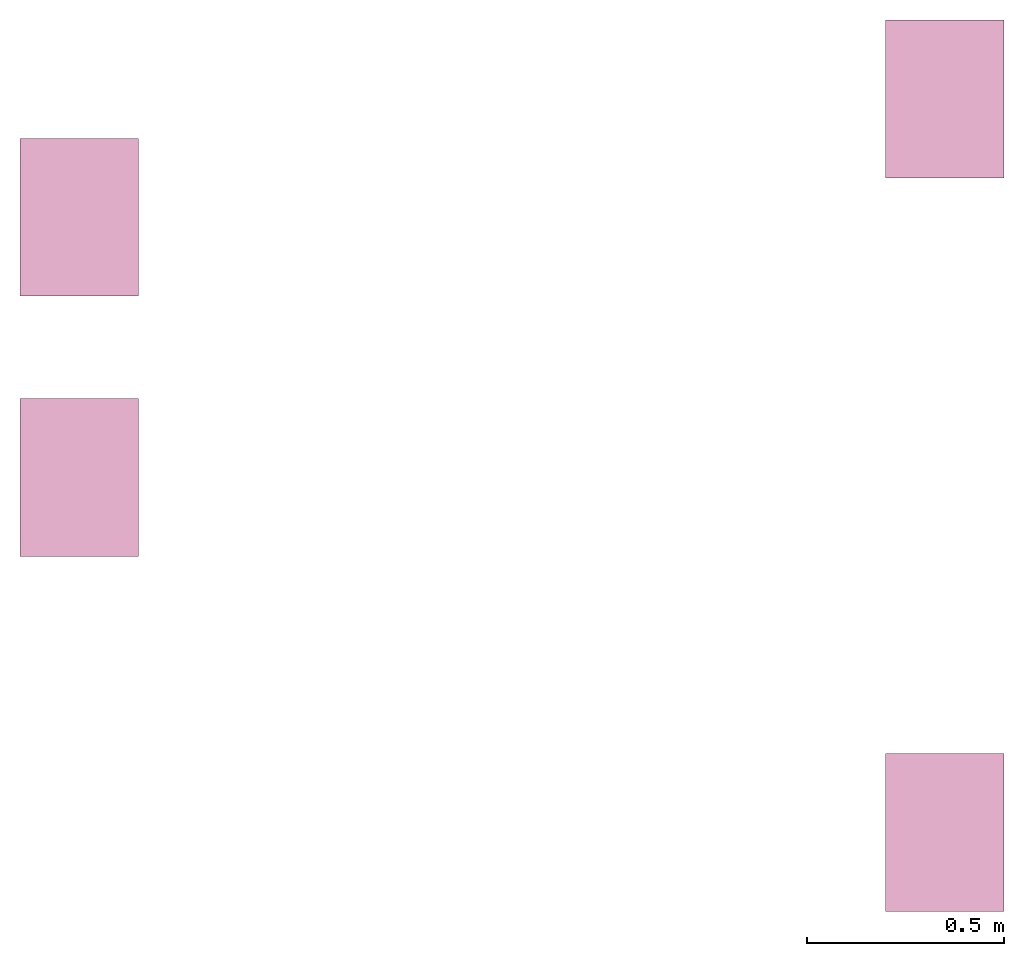
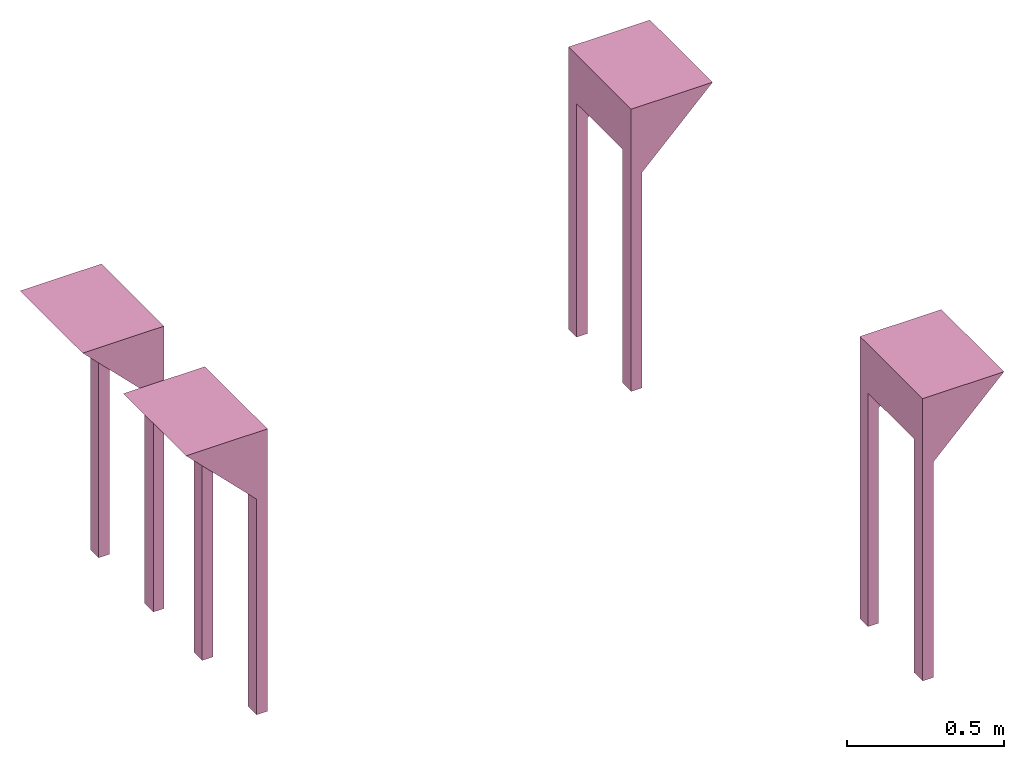
# One storey: 4 furnishings.
"""IFC2X3 building model written with IfcOpenShell, lengths in millimetres."""

from ifc_helpers import new_model, entity, si_unit, converted_unit, money_unit, direction, frame, origin_with_axes, place, context, subcontext, project, spatial, faceted_brep, source, transform, mapped, material, type_object, element, save


model = new_model("IFC2X3")

# Units and contexts
model_context = context("Model", 3, precision=1e-05, world=origin_with_axes(), true_north=direction((0.0, 1.0)))
body_context = subcontext(model_context, "Body", "Model", "MODEL_VIEW")
ifc_project = project(units=[si_unit("LENGTHUNIT", "METRE", prefix="MILLI"), si_unit("AREAUNIT", "SQUARE_METRE"), si_unit("VOLUMEUNIT", "CUBIC_METRE"), converted_unit("PLANEANGLEUNIT", "DEGREE", entity("IfcPlaneAngleMeasure", 0.0174532925199), si_unit("PLANEANGLEUNIT", "RADIAN"), dimensions=[0, 0, 0, 0, 0, 0, 0]), si_unit("SOLIDANGLEUNIT", "STERADIAN"), money_unit("USD"), converted_unit("TIMEUNIT", "Year", entity("IfcTimeMeasure", 31556926.0), si_unit("TIMEUNIT", "SECOND"), dimensions=[0, 0, 0, 0, 0, 0, 0]), si_unit("MASSUNIT", "GRAM"), si_unit("THERMODYNAMICTEMPERATUREUNIT", "DEGREE_CELSIUS"), si_unit("LUMINOUSINTENSITYUNIT", "LUMEN")], contexts=[model_context])

# Site, building, storey
site_placement = place(None, origin_with_axes())
site = spatial("IfcSite", under=ifc_project, at=site_placement, CompositionType="ELEMENT")
building_placement = place(site_placement, origin_with_axes())
building = spatial("IfcBuilding", under=site, at=building_placement, CompositionType="ELEMENT")
storey_placement = place(building_placement, frame((0.0, 0.0, 70800.0), z_axis=(0.0, 0.0, 1.0), x_axis=(1.0, 0.0, 0.0)))
storey = spatial("IfcBuildingStorey", under=building, at=storey_placement, CompositionType="ELEMENT", Elevation=70800.0)

# Furnishings
ifc_material = material(Name="Galv Mild Steel")
furniture_type_1 = type_object("IfcFurnitureType", Name="Pump Stand", AssemblyPlace="NOTDEFINED")
shared_shape_1 = source(origin_with_axes(), body_context, "Body", "Brep", [
    faceted_brep([(0.0, 0.0, 1100.0), (0.0, 0.0, 0.0), (39.558800933, 0.0, 0.0), (39.558800933, 0.0, 839.558800933), (300.0, 0.0, 1100.0), (0.0, 400.0, 1100.0), (0.0, 400.0, 0.0), (0.0, 348.624416492, 0.0), (0.0, 348.624416492, 910.460081542), (0.0, 55.7857203565, 910.460081542), (0.0, 55.7857203565, 0.0), (39.558800933, 55.7857203565, 0.0), (39.558800933, 55.7857203565, 839.558800933), (110.460081542, 55.7857203565, 910.460081542), (110.460081542, 348.624416492, 910.460081542), (39.558800933, 348.624416492, 839.558800933), (39.558800933, 400.0, 839.558800933), (300.0, 400.0, 1100.0), (39.558800933, 400.0, 0.0), (39.558800933, 348.624416492, 0.0)], [[[0, 1, 2, 3, 4]], [[1, 0, 5, 6, 7, 8, 9, 10]], [[2, 1, 10, 11]], [[3, 2, 11, 12]], [[4, 3, 12, 13, 14, 15, 16, 17]], [[0, 4, 17, 5]], [[5, 17, 16, 18, 6]], [[6, 18, 19, 7]], [[14, 8, 7, 19, 15]], [[8, 14, 13, 9]], [[9, 13, 12, 11, 10]], [[18, 16, 15, 19]]]),
])
furnishing_1_placement = place(storey_placement, frame((8913.79615184, -236.19512708, -100.0), z_axis=(0.0, 0.0, 1.0), x_axis=(1.0, 0.0, 0.0)))
element("IfcFurnishingElement", 1, at=furnishing_1_placement, inside=storey, type_object=furniture_type_1, material=ifc_material, Name="Pump Stand4:Pump Stand", ObjectType="Pump Stand", context=body_context, shape_type="MappedRepresentation", body=[
    mapped(shared_shape_1, transform((0.0, 0.0, 0.0))),
])
furniture_type_2 = type_object("IfcFurnitureType", Name="Pump Stand", AssemblyPlace="NOTDEFINED")
furnishing_2_placement = place(storey_placement, frame((8913.79615184, 1623.80487292, -100.0), z_axis=(0.0, 0.0, 1.0), x_axis=(1.0, 0.0, 0.0)))
element("IfcFurnishingElement", 2, at=furnishing_2_placement, inside=storey, type_object=furniture_type_2, material=ifc_material, Name="Pump Stand5:Pump Stand", ObjectType="Pump Stand", context=body_context, shape_type="MappedRepresentation", body=[
    mapped(shared_shape_1, transform((0.0, 0.0, 0.0))),
])
furniture_type_3 = type_object("IfcFurnitureType", Name="Pump Stand", AssemblyPlace="NOTDEFINED")
shared_shape_2 = source(origin_with_axes(), body_context, "Body", "Brep", [
    faceted_brep([(300.000043889, 3.291697e-05, 1100.0), (4.388929e-05, 0.0, 1100.0), (260.441242956, 2.857645e-05, 839.558800933), (260.441242956, 2.857645e-05, 0.0), (300.000043889, 3.291697e-05, 0.0), (300.0, 400.000032917, 1100.0), (0.0, 400.0, 1100.0), (260.441199067, 400.000028576, 839.558800933), (260.441204704, 348.624445069, 839.558800933), (189.539924095, 348.624437289, 910.460081542), (189.539956226, 55.7857411534, 910.460081542), (260.441236835, 55.785748933, 839.558800933), (260.441236835, 55.785748933, 0.0), (300.000037768, 55.7857532735, 0.0), (300.000037768, 55.7857532735, 910.460081542), (300.000005637, 348.624449409, 910.460081542), (300.000005637, 348.624449409, 0.0), (300.0, 400.000032917, 0.0), (260.441199067, 400.000028576, 0.0), (260.441204704, 348.624445069, 0.0)], [[[0, 1, 2, 3, 4]], [[1, 0, 5, 6]], [[2, 1, 6, 7, 8, 9, 10, 11]], [[3, 2, 11, 12]], [[4, 3, 12, 13]], [[0, 4, 13, 14, 15, 16, 17, 5]], [[5, 17, 18, 7, 6]], [[7, 18, 19, 8]], [[15, 9, 8, 19, 16]], [[9, 15, 14, 10]], [[10, 14, 13, 12, 11]], [[18, 17, 16, 19]]]),
])
furnishing_3_placement = place(storey_placement, frame((6719.12801216, 663.804728378, -100.0), z_axis=(0.0, 0.0, 1.0), x_axis=(1.0, 0.0, 0.0)))
element("IfcFurnishingElement", 3, at=furnishing_3_placement, inside=storey, type_object=furniture_type_3, material=ifc_material, Name="Pump Stand6:Pump Stand", ObjectType="Pump Stand", context=body_context, shape_type="MappedRepresentation", body=[
    mapped(shared_shape_2, transform((0.0, 0.0, 0.0))),
])
furniture_type_4 = type_object("IfcFurnitureType", Name="Pump Stand", AssemblyPlace="NOTDEFINED")
furnishing_4_placement = place(storey_placement, frame((6719.12780808, 1323.80472838, -100.0), z_axis=(0.0, 0.0, 1.0), x_axis=(1.0, 0.0, 0.0)))
element("IfcFurnishingElement", 4, at=furnishing_4_placement, inside=storey, type_object=furniture_type_4, material=ifc_material, Name="Pump Stand7:Pump Stand", ObjectType="Pump Stand", context=body_context, shape_type="MappedRepresentation", body=[
    mapped(shared_shape_2, transform((0.0, 0.0, 0.0))),
])

save(model, "model.ifc")
